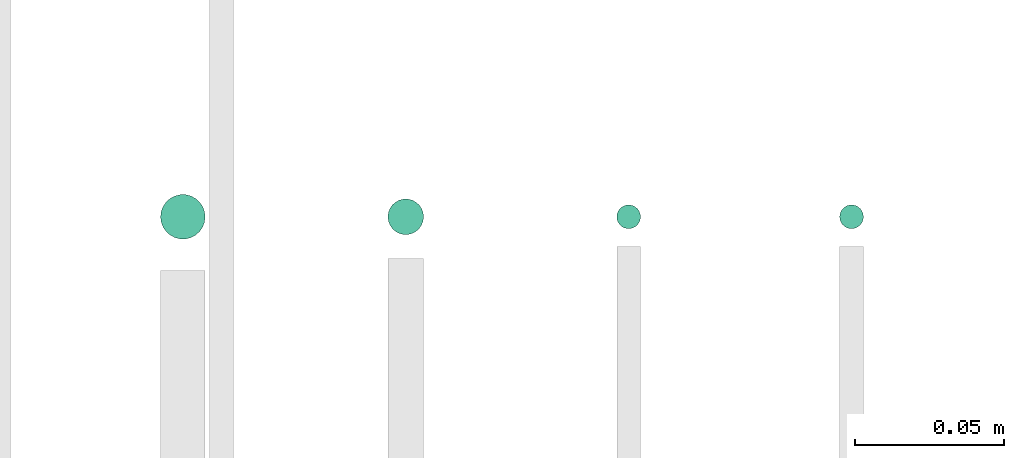
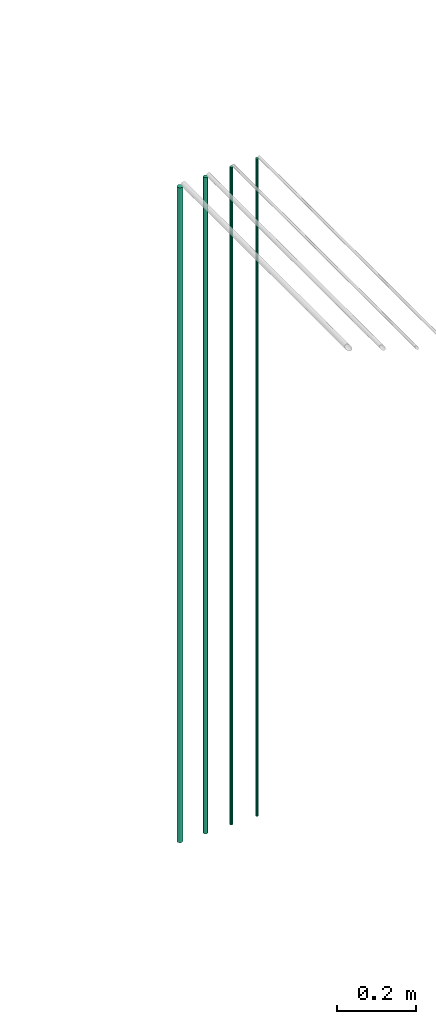
# One storey, part 113 of 331: 4 flow segments.
"""IFC2X3 building model written with IfcOpenShell, lengths in millimetres."""

from ifc_helpers import new_model, entity, si_unit, converted_unit, derived_unit, direction, frame, origin, origin_2d_with_axis, place, context, subcontext, project, spatial, circle, extrude, type_object, element, save


model = new_model("IFC2X3")

# Units and contexts
model_context = context("Model", 3, precision=0.01, world=origin(), true_north=direction((6.12303176911189e-17, 1.0)))
body_context = subcontext(model_context, "Body", "Model", "MODEL_VIEW")
ifc_project = project(units=[si_unit("LENGTHUNIT", "METRE", prefix="MILLI"), si_unit("AREAUNIT", "SQUARE_METRE"), si_unit("VOLUMEUNIT", "CUBIC_METRE"), converted_unit("PLANEANGLEUNIT", "DEGREE", entity("IfcRatioMeasure", 0.0174532925199433), si_unit("PLANEANGLEUNIT", "RADIAN"), dimensions=[0, 0, 0, 0, 0, 0, 0]), si_unit("MASSUNIT", "GRAM", prefix="KILO"), derived_unit("MASSDENSITYUNIT", [(si_unit("MASSUNIT", "GRAM", prefix="KILO"), 1), (si_unit("LENGTHUNIT", "METRE"), -3)]), derived_unit("MOMENTOFINERTIAUNIT", [(si_unit("LENGTHUNIT", "METRE"), 4)]), si_unit("TIMEUNIT", "SECOND"), si_unit("FREQUENCYUNIT", "HERTZ"), si_unit("THERMODYNAMICTEMPERATUREUNIT", "DEGREE_CELSIUS"), derived_unit("THERMALTRANSMITTANCEUNIT", [(si_unit("MASSUNIT", "GRAM", prefix="KILO"), 1), (si_unit("THERMODYNAMICTEMPERATUREUNIT", "KELVIN"), -1), (si_unit("TIMEUNIT", "SECOND"), -3)]), derived_unit("VOLUMETRICFLOWRATEUNIT", [(si_unit("LENGTHUNIT", "METRE"), 3), (si_unit("TIMEUNIT", "SECOND"), -1)]), derived_unit("MASSFLOWRATEUNIT", [(si_unit("MASSUNIT", "GRAM", prefix="KILO"), 1), (si_unit("TIMEUNIT", "SECOND"), -1)]), derived_unit("ROTATIONALFREQUENCYUNIT", [(si_unit("TIMEUNIT", "SECOND"), -1)]), si_unit("ELECTRICCURRENTUNIT", "AMPERE"), si_unit("ELECTRICVOLTAGEUNIT", "VOLT"), si_unit("POWERUNIT", "WATT"), si_unit("FORCEUNIT", "NEWTON", prefix="KILO"), si_unit("ILLUMINANCEUNIT", "LUX"), si_unit("LUMINOUSFLUXUNIT", "LUMEN"), si_unit("LUMINOUSINTENSITYUNIT", "CANDELA"), derived_unit("USERDEFINED", [(si_unit("MASSUNIT", "GRAM", prefix="KILO"), -1), (si_unit("LENGTHUNIT", "METRE"), -2), (si_unit("TIMEUNIT", "SECOND"), 3), (si_unit("LUMINOUSFLUXUNIT", "LUMEN"), 1)]), derived_unit("LINEARVELOCITYUNIT", [(si_unit("LENGTHUNIT", "METRE"), 1), (si_unit("TIMEUNIT", "SECOND"), -1)]), si_unit("PRESSUREUNIT", "PASCAL"), derived_unit("USERDEFINED", [(si_unit("LENGTHUNIT", "METRE"), -2), (si_unit("MASSUNIT", "GRAM", prefix="KILO"), 1), (si_unit("TIMEUNIT", "SECOND"), -2)]), derived_unit("LINEARFORCEUNIT", [(si_unit("MASSUNIT", "GRAM", prefix="KILO"), 1), (si_unit("LENGTHUNIT", "METRE"), 1), (si_unit("TIMEUNIT", "SECOND"), -2), (si_unit("LENGTHUNIT", "METRE"), -1)]), derived_unit("PLANARFORCEUNIT", [(si_unit("MASSUNIT", "GRAM", prefix="KILO"), 1), (si_unit("LENGTHUNIT", "METRE"), 1), (si_unit("TIMEUNIT", "SECOND"), -2), (si_unit("LENGTHUNIT", "METRE"), -2)])], contexts=[model_context])

# Site, building, storey
site_placement = place(None, frame((0.0, -0.00077364408347762, 0.0)))
site = spatial("IfcSite", under=ifc_project, at=site_placement, CompositionType="ELEMENT")
building_placement = place(site_placement, origin())
building = spatial("IfcBuilding", under=site, at=building_placement, CompositionType="ELEMENT")
storey_placement = place(building_placement, origin())
storey = spatial("IfcBuildingStorey", under=building, at=storey_placement, CompositionType="ELEMENT", Elevation=0.0)

# Flow segments
pipe_segment_type = type_object("IfcPipeSegmentType", PredefinedType="NOTDEFINED")
flow_segment_1_placement = place(storey_placement, frame((60011.0132627125, 18922.5252915915, 13110.0)))
element("IfcFlowSegment", 1, at=flow_segment_1_placement, inside=storey, type_object=pipe_segment_type, context=body_context, shape_type="SweptSolid", body=[
    extrude(circle(Radius=7.5, at=origin_2d_with_axis()), frame((9.09527223591419, 9.09527223591636, 0.0)), (0.0, 0.0, 1.0), 2022.0),
])
flow_segment_2_placement = place(storey_placement, frame((60087.5132627125, 18924.0252915915, 13110.0)))
element("IfcFlowSegment", 2, at=flow_segment_2_placement, inside=storey, type_object=pipe_segment_type, context=body_context, shape_type="SweptSolid", body=[
    extrude(circle(Radius=6.0, at=origin_2d_with_axis()), frame((7.59527223591454, 7.5952722359167, 0.0)), (0.0, 0.0, 1.0), 2026.0),
])
for number, where in (
    (3, (60164.5132627125, 18926.0252915915, 13110.0)),
    (4, (60239.5132627125, 18926.0252915915, 13110.0)),
):
    element("IfcFlowSegment", number, at=place(storey_placement, frame(where)), inside=storey, type_object=pipe_segment_type, context=body_context, shape_type="SweptSolid", body=[
        extrude(circle(Radius=4.0, at=origin_2d_with_axis()), frame((5.59527223591499, 5.59527223591499, 0.0)), (0.0, 0.0, 1.0), 2030.0),
    ])

save(model, "model.ifc")
